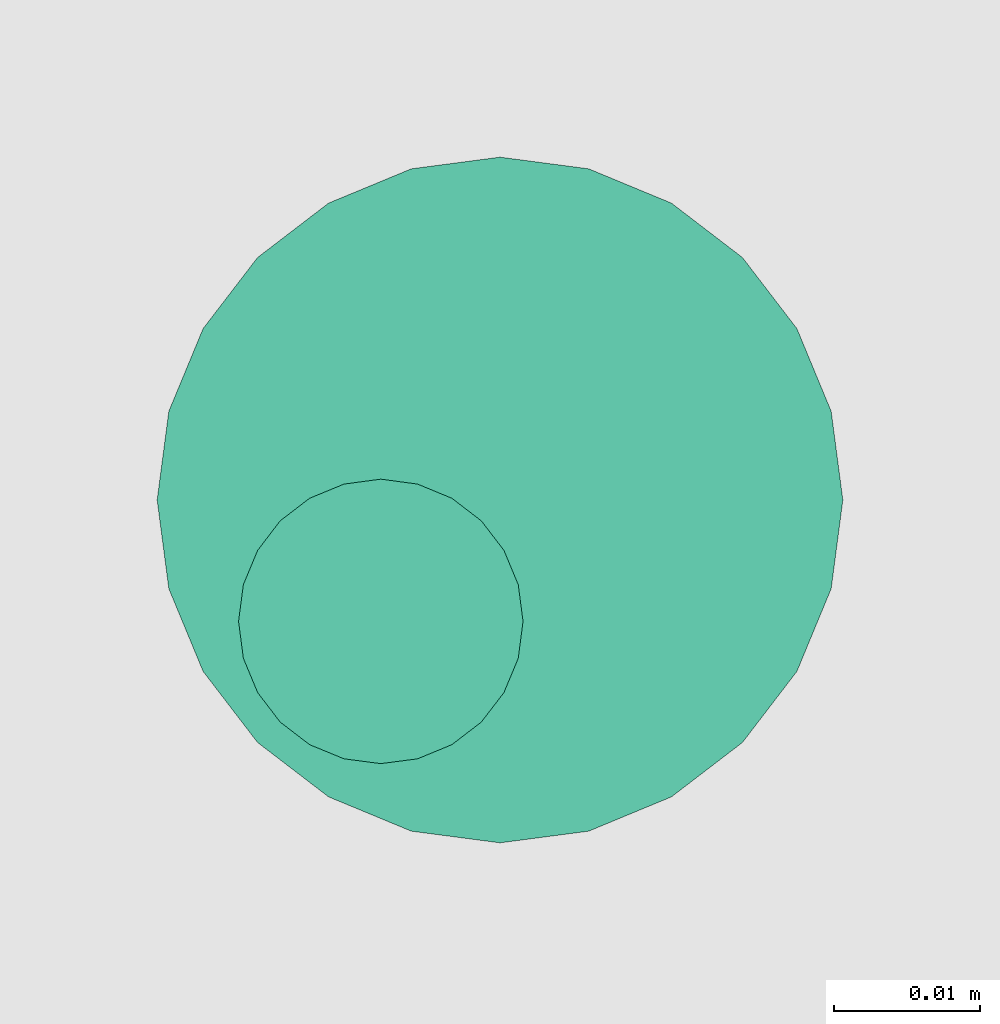
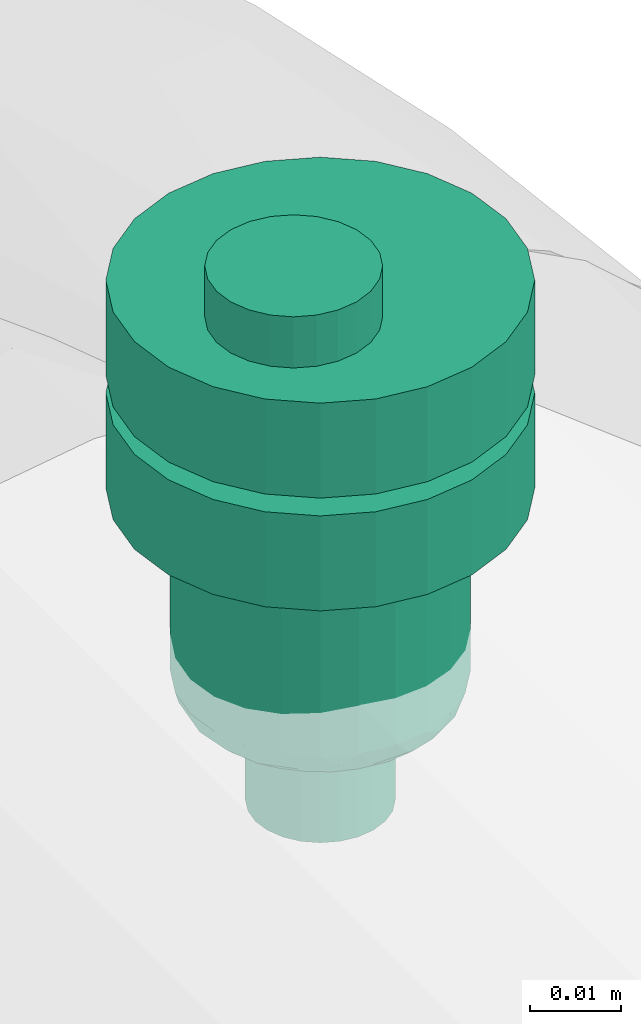
# One storey, part 559 of 827: 1 flow controller.
"""IFC2X3 building model written with IfcOpenShell, lengths in millimetres."""

from ifc_helpers import new_model, entity, si_unit, converted_unit, derived_unit, direction, frame, origin, place, context, subcontext, project, spatial, faceted_brep, source, transform, mapped, material, type_object, type_shapes, element, save


model = new_model("IFC2X3")

# Units and contexts
model_context = context("Model", 3, precision=0.01, world=origin(), true_north=direction((6.12303176911189e-17, 1.0)))
body_context = subcontext(model_context, "Body", "Model", "MODEL_VIEW")
ifc_project = project(units=[si_unit("LENGTHUNIT", "METRE", prefix="MILLI"), si_unit("AREAUNIT", "SQUARE_METRE"), si_unit("VOLUMEUNIT", "CUBIC_METRE"), converted_unit("PLANEANGLEUNIT", "DEGREE", entity("IfcRatioMeasure", 0.0174532925199433), si_unit("PLANEANGLEUNIT", "RADIAN"), dimensions=[0, 0, 0, 0, 0, 0, 0]), si_unit("MASSUNIT", "GRAM", prefix="KILO"), derived_unit("MASSDENSITYUNIT", [(si_unit("MASSUNIT", "GRAM", prefix="KILO"), 1), (si_unit("LENGTHUNIT", "METRE"), -3)]), derived_unit("MOMENTOFINERTIAUNIT", [(si_unit("LENGTHUNIT", "METRE"), 4)]), si_unit("TIMEUNIT", "SECOND"), si_unit("FREQUENCYUNIT", "HERTZ"), si_unit("THERMODYNAMICTEMPERATUREUNIT", "DEGREE_CELSIUS"), derived_unit("THERMALTRANSMITTANCEUNIT", [(si_unit("MASSUNIT", "GRAM", prefix="KILO"), 1), (si_unit("THERMODYNAMICTEMPERATUREUNIT", "KELVIN"), -1), (si_unit("TIMEUNIT", "SECOND"), -3)]), derived_unit("VOLUMETRICFLOWRATEUNIT", [(si_unit("LENGTHUNIT", "METRE"), 3), (si_unit("TIMEUNIT", "SECOND"), -1)]), derived_unit("MASSFLOWRATEUNIT", [(si_unit("MASSUNIT", "GRAM", prefix="KILO"), 1), (si_unit("TIMEUNIT", "SECOND"), -1)]), derived_unit("ROTATIONALFREQUENCYUNIT", [(si_unit("TIMEUNIT", "SECOND"), -1)]), si_unit("ELECTRICCURRENTUNIT", "AMPERE"), si_unit("ELECTRICVOLTAGEUNIT", "VOLT"), si_unit("POWERUNIT", "WATT"), si_unit("FORCEUNIT", "NEWTON", prefix="KILO"), si_unit("ILLUMINANCEUNIT", "LUX"), si_unit("LUMINOUSFLUXUNIT", "LUMEN"), si_unit("LUMINOUSINTENSITYUNIT", "CANDELA"), derived_unit("USERDEFINED", [(si_unit("MASSUNIT", "GRAM", prefix="KILO"), -1), (si_unit("LENGTHUNIT", "METRE"), -2), (si_unit("TIMEUNIT", "SECOND"), 3), (si_unit("LUMINOUSFLUXUNIT", "LUMEN"), 1)]), derived_unit("LINEARVELOCITYUNIT", [(si_unit("LENGTHUNIT", "METRE"), 1), (si_unit("TIMEUNIT", "SECOND"), -1)]), si_unit("PRESSUREUNIT", "PASCAL"), derived_unit("USERDEFINED", [(si_unit("LENGTHUNIT", "METRE"), -2), (si_unit("MASSUNIT", "GRAM", prefix="KILO"), 1), (si_unit("TIMEUNIT", "SECOND"), -2)]), derived_unit("LINEARFORCEUNIT", [(si_unit("MASSUNIT", "GRAM", prefix="KILO"), 1), (si_unit("LENGTHUNIT", "METRE"), 1), (si_unit("TIMEUNIT", "SECOND"), -2), (si_unit("LENGTHUNIT", "METRE"), -1)]), derived_unit("PLANARFORCEUNIT", [(si_unit("MASSUNIT", "GRAM", prefix="KILO"), 1), (si_unit("LENGTHUNIT", "METRE"), 1), (si_unit("TIMEUNIT", "SECOND"), -2), (si_unit("LENGTHUNIT", "METRE"), -2)])], contexts=[model_context])

# Site, building, storey
site_placement = place(None, origin())
site = spatial("IfcSite", under=ifc_project, at=site_placement, CompositionType="ELEMENT")
building_placement = place(site_placement, origin())
building = spatial("IfcBuilding", under=site, at=building_placement, CompositionType="ELEMENT")
storey_placement = place(building_placement, frame((0.0, 0.0, 28200.0)))
storey = spatial("IfcBuildingStorey", under=building, at=storey_placement, Name="08", CompositionType="ELEMENT", Elevation=28200.0)

# Flow controller
ifc_material = material()
valve_type = type_object("IfcValveType", PredefinedType="NOTDEFINED", material=ifc_material)
shared_shape = source(origin(), body_context, "Body", "Brep", [
    faceted_brep([(-6.86, -13.27, -15.58), (-5.66, -12.77, -15.58), (-5.66, -12.77, -13.2), (-6.86, -13.27, -13.2), (-6.86, -13.27, -0.5), (-5.66, -12.77, -0.5), (-5.66, -12.77, 2.49), (-6.86, -13.27, 2.49), (-8.16, -13.44, -15.58), (-8.16, -13.44, -13.2), (-8.16, -13.44, -0.5), (-8.16, -13.44, 2.49), (-3.83, -10.94, -15.58), (-3.33, -9.74, -15.58), (-3.33, -9.74, -13.2), (-3.83, -10.94, -13.2), (-3.83, -10.94, -0.5), (-3.33, -9.74, -0.5), (-3.33, -9.74, 2.49), (-3.83, -10.94, 2.49), (-4.62, -11.98, -15.58), (-4.62, -11.98, -13.2), (-4.62, -11.98, -0.5), (-4.62, -11.98, 2.49), (-3.16, -8.44, -13.2), (-3.16, -8.44, -15.58), (-3.16, -8.44, 2.49), (-3.16, -8.44, -0.5), (-3.83, -5.94, -15.58), (-4.62, -4.91, -15.58), (-4.62, -4.91, -13.2), (-3.83, -5.94, -13.2), (-3.83, -5.94, -0.5), (-4.62, -4.91, -0.5), (-4.62, -4.91, 2.49), (-3.83, -5.94, 2.49), (-3.33, -7.15, -15.58), (-3.33, -7.15, -13.2), (-3.33, -7.15, -0.5), (-3.33, -7.15, 2.49), (-6.86, -3.61, -15.58), (-8.16, -3.44, -15.58), (-8.16, -3.44, -13.2), (-6.86, -3.61, -13.2), (-6.86, -3.61, -0.5), (-8.16, -3.44, -0.5), (-8.16, -3.44, 2.49), (-6.86, -3.61, 2.49), (-5.66, -4.11, -15.58), (-5.66, -4.11, -13.2), (-5.66, -4.11, -0.5), (-5.66, -4.11, 2.49), (-9.45, -3.61, -0.5), (-9.45, -3.61, 2.49), (-9.45, -3.61, -15.58), (-9.45, -3.61, -13.2), (-10.66, -4.11, -0.5), (-10.66, -4.11, 2.49), (-10.66, -4.11, -15.58), (-10.66, -4.11, -13.2), (-12.49, -5.94, 2.49), (-11.69, -4.91, 2.49), (-11.69, -4.91, -0.5), (-12.49, -5.94, -0.5), (-11.69, -4.91, -15.58), (-12.49, -5.94, -15.58), (-12.49, -5.94, -13.2), (-11.69, -4.91, -13.2), (-12.99, -7.15, 2.49), (-12.99, -7.15, -0.5), (-12.99, -7.15, -15.58), (-12.99, -7.15, -13.2), (-13.16, -8.44, 2.49), (-13.16, -8.44, -0.5), (-13.16, -8.44, -13.2), (-13.16, -8.44, -15.58), (-12.49, -10.94, -0.5), (-12.49, -10.94, 2.49), (-12.99, -9.74, 2.49), (-12.99, -9.74, -0.5), (-12.99, -9.74, -15.58), (-12.49, -10.94, -15.58), (-12.49, -10.94, -13.2), (-12.99, -9.74, -13.2), (-11.69, -11.98, -0.5), (-11.69, -11.98, 2.49), (-11.69, -11.98, -15.58), (-11.69, -11.98, -13.2), (-9.45, -13.27, 2.49), (-10.66, -12.77, 2.49), (-10.66, -12.77, -0.5), (-9.45, -13.27, -0.5), (-10.66, -12.77, -15.58), (-9.45, -13.27, -15.58), (-9.45, -13.27, -13.2), (-10.66, -12.77, -13.2), (6.08, -22.7, -0.5), (0.0, -23.5, -0.5), (11.75, -20.35, -0.5), (16.62, -16.62, -0.5), (20.35, -11.75, -0.5), (22.7, -6.08, -0.5), (23.5, 0.0, -0.5), (22.7, 6.08, -0.5), (20.35, 11.75, -0.5), (16.62, 16.62, -0.5), (11.75, 20.35, -0.5), (6.08, 22.7, -0.5), (0.0, 23.5, -0.5), (-6.08, 22.7, -0.5), (-11.75, 20.35, -0.5), (-16.62, 16.62, -0.5), (-20.35, 11.75, -0.5), (-22.7, 6.08, -0.5), (-23.5, 0.0, -0.5), (-22.7, -6.08, -0.5), (-20.35, -11.75, -0.5), (-16.62, -16.62, -0.5), (-11.75, -20.35, -0.5), (-6.08, -22.7, -0.5), (11.75, 20.35, -13.2), (6.08, 22.7, -13.2), (16.62, 16.62, -13.2), (20.35, 11.75, -13.2), (22.7, 6.08, -13.2), (23.5, 0.0, -13.2), (22.7, -6.08, -13.2), (20.35, -11.75, -13.2), (16.62, -16.62, -13.2), (11.75, -20.35, -13.2), (6.08, -22.7, -13.2), (0.0, -23.5, -13.2), (-6.08, -22.7, -13.2), (-11.75, -20.35, -13.2), (-16.62, -16.62, -13.2), (-20.35, -11.75, -13.2), (-22.7, -6.08, -13.2), (-23.5, 0.0, -13.2), (-22.7, 6.08, -13.2), (-20.35, 11.75, -13.2), (-16.62, 16.62, -13.2), (-11.75, 20.35, -13.2), (-6.08, 22.7, -13.2), (0.0, 23.5, -13.2), (-22.7, -6.08, -28.28), (-22.7, -6.08, -15.58), (-23.5, 0.0, -15.58), (-23.5, 0.0, -28.28), (-20.35, -11.75, -28.28), (-20.35, -11.75, -15.58), (-11.75, -20.35, -15.58), (-16.62, -16.62, -15.58), (-16.62, -16.62, -28.28), (-11.75, -20.35, -28.28), (-6.08, -22.7, -15.58), (-6.08, -22.7, -28.28), (0.0, -23.5, -15.58), (0.0, -23.5, -28.28), (6.08, -22.7, -28.28), (6.08, -22.7, -15.58), (11.75, -20.35, -28.28), (11.75, -20.35, -15.58), (20.35, -11.75, -15.58), (16.62, -16.62, -15.58), (16.62, -16.62, -28.28), (20.35, -11.75, -28.28), (22.7, -6.08, -15.58), (22.7, -6.08, -28.28), (23.5, 0.0, -15.58), (23.5, 0.0, -28.28), (22.7, 6.08, -28.28), (22.7, 6.08, -15.58), (20.35, 11.75, -28.28), (20.35, 11.75, -15.58), (11.75, 20.35, -15.58), (16.62, 16.62, -15.58), (16.62, 16.62, -28.28), (11.75, 20.35, -28.28), (6.08, 22.7, -15.58), (6.08, 22.7, -28.28), (0.0, 23.5, -15.58), (0.0, 23.5, -28.28), (-6.08, 22.7, -28.28), (-6.08, 22.7, -15.58), (-11.75, 20.35, -28.28), (-11.75, 20.35, -15.58), (-20.35, 11.75, -15.58), (-16.62, 16.62, -15.58), (-16.62, 16.62, -28.28), (-20.35, 11.75, -28.28), (-22.7, 6.08, -15.58), (-22.7, 6.08, -28.28), (8.23, 14.25, -28.28), (4.26, 15.89, -28.28), (11.63, 11.63, -28.28), (14.25, 8.22, -28.28), (15.89, 4.26, -28.28), (16.45, 0.0, -28.28), (15.89, -4.26, -28.28), (14.25, -8.23, -28.28), (11.63, -11.63, -28.28), (8.23, -14.25, -28.28), (4.26, -15.89, -28.28), (0.0, -16.45, -28.28), (-4.26, -15.89, -28.28), (-8.22, -14.25, -28.28), (-11.63, -11.63, -28.28), (-14.25, -8.23, -28.28), (-15.89, -4.26, -28.28), (-16.45, 0.0, -28.28), (-15.89, 4.26, -28.28), (-14.25, 8.22, -28.28), (-11.63, 11.63, -28.28), (-8.22, 14.25, -28.28), (-4.26, 15.89, -28.28), (0.0, 16.45, -28.28), (-15.89, -4.26, -52.7), (-16.45, 0.0, -52.7), (-14.25, -8.23, -52.7), (-11.63, -11.63, -52.7), (-8.22, -14.25, -52.7), (-4.26, -15.89, -52.7), (0.0, -16.45, -52.7), (4.26, -15.89, -52.7), (8.23, -14.25, -52.7), (11.63, -11.63, -52.7), (14.25, -8.23, -52.7), (15.89, -4.26, -52.7), (16.45, 0.0, -52.7), (15.89, 4.26, -52.7), (14.25, 8.22, -52.7), (11.63, 11.63, -52.7), (8.23, 14.25, -52.7), (4.26, 15.89, -52.7), (0.0, 16.45, -52.7), (-4.26, 15.89, -52.7), (-8.22, 14.25, -52.7), (-11.63, 11.63, -52.7), (-14.25, 8.22, -52.7), (-15.89, 4.26, -52.7), (10.61, 9.36, -56.39), (8.29, 11.45, -56.39), (9.98, 12.23, -54.94), (-13.58, 4.48, -56.31), (-14.89, 5.25, -54.94), (-12.77, 8.5, -55.51), (6.32, 14.92, -54.11), (-3.39, 14.2, -56.13), (-6.26, 13.77, -55.71), (-2.15, 15.69, -54.85), (2.15, 15.59, -55.0), (10.54, 4.37, -56.8), (12.15, 6.9, -56.46), (14.89, 5.25, -54.94), (13.8, 0.0, -56.2), (13.58, 4.48, -56.31), (12.77, 8.5, -55.51), (15.25, 0.0, -55.6), (-9.98, 12.23, -54.94), (6.26, 13.77, -55.71), (4.37, 10.54, -56.8), (3.28, 13.85, -56.34), (-15.25, 0.0, -55.6), (-6.32, 14.92, -54.11), (-10.54, 4.37, -56.8), (-12.35, 0.0, -56.8), (-12.15, 6.9, -56.46), (-10.61, 9.36, -56.39), (8.73, 8.73, -56.8), (-4.37, 10.54, -56.8), (-6.55, 9.64, -56.8), (-13.8, 0.0, -56.2), (-0.21, 14.49, -56.2), (0.0, 12.35, -56.8), (-8.73, 8.73, -56.8), (-8.29, 11.45, -56.39), (12.35, 0.0, -56.8), (-10.61, -9.36, -56.39), (-8.29, -11.45, -56.39), (-9.98, -12.23, -54.94), (13.58, -4.48, -56.31), (14.89, -5.25, -54.94), (12.77, -8.5, -55.51), (-6.32, -14.92, -54.11), (6.32, -14.92, -54.11), (9.98, -12.23, -54.94), (-2.15, -15.59, -55.0), (-10.54, -4.37, -56.8), (-12.15, -6.9, -56.46), (-12.77, -8.5, -55.51), (2.15, -15.69, -54.85), (-14.89, -5.25, -54.94), (-13.58, -4.48, -56.31), (-8.73, -8.73, -56.8), (6.26, -13.77, -55.71), (4.37, -10.54, -56.8), (6.55, -9.64, -56.8), (12.15, -6.9, -56.46), (10.61, -9.36, -56.39), (10.54, -4.37, -56.8), (-6.26, -13.77, -55.71), (-4.37, -10.54, -56.8), (-3.28, -13.85, -56.34), (3.39, -14.2, -56.13), (0.21, -14.49, -56.2), (0.0, -12.35, -56.8), (8.73, -8.73, -56.8), (8.29, -11.45, -56.39), (-7.94, 2.13, -56.8), (-8.22, 0.0, -56.8), (-7.12, 4.11, -56.8), (-7.94, -2.13, -56.8), (-7.12, -4.11, -56.8), (-5.82, -5.82, -56.8), (-4.11, -7.12, -56.8), (-2.13, -7.94, -56.8), (0.0, -8.23, -56.8), (2.13, -7.94, -56.8), (4.11, -7.12, -56.8), (5.82, -5.82, -56.8), (7.12, -4.11, -56.8), (7.94, -2.13, -56.8), (8.23, 0.0, -56.8), (7.94, 2.13, -56.8), (7.12, 4.11, -56.8), (5.82, 5.82, -56.8), (4.11, 7.12, -56.8), (2.13, 7.94, -56.8), (0.0, 8.22, -56.8), (-2.13, 7.94, -56.8), (-4.11, 7.12, -56.8), (-5.82, 5.82, -56.8), (0.0, 8.22, -70.0), (2.13, 7.94, -70.0), (4.11, 7.12, -70.0), (5.82, 5.82, -70.0), (7.12, 4.11, -70.0), (7.94, 2.13, -70.0), (8.23, 0.0, -70.0), (7.94, -2.13, -70.0), (7.12, -4.11, -70.0), (5.82, -5.82, -70.0), (4.11, -7.12, -70.0), (2.13, -7.94, -70.0), (0.0, -8.23, -70.0), (-2.13, -7.94, -70.0), (-4.11, -7.12, -70.0), (-5.82, -5.82, -70.0), (-7.12, -4.11, -70.0), (-7.94, -2.13, -70.0), (-8.22, 0.0, -70.0), (-7.94, 2.13, -70.0), (-7.12, 4.11, -70.0), (-5.82, 5.82, -70.0), (-4.11, 7.12, -70.0), (-2.13, 7.94, -70.0), (1.25, -5.8, 9.33), (0.27, -3.45, 9.33), (-1.28, -1.43, 9.33), (-3.3, 0.12, 9.33), (-5.65, 1.09, 9.33), (-8.17, 1.43, 9.33), (-10.69, 1.09, 9.33), (-13.05, 0.12, 9.33), (-15.07, -1.43, 9.33), (-16.61, -3.45, 9.33), (-17.59, -5.8, 9.33), (-17.92, -8.32, 9.33), (-17.59, -10.85, 9.33), (-16.61, -13.2, 9.33), (-15.07, -15.22, 9.33), (-13.05, -16.77, 9.33), (-10.69, -17.74, 9.33), (-8.17, -18.07, 9.33), (-5.65, -17.74, 9.33), (-3.3, -16.77, 9.33), (-1.28, -15.22, 9.33), (0.27, -13.2, 9.33), (1.25, -10.85, 9.33), (1.58, -8.32, 9.33), (-16.61, -3.45, 2.49), (-17.59, -5.8, 2.49), (-15.07, -1.43, 2.49), (-13.05, 0.12, 2.49), (-10.69, 1.09, 2.49), (-8.17, 1.43, 2.49), (-5.65, 1.09, 2.49), (-3.3, 0.12, 2.49), (-1.28, -1.43, 2.49), (0.27, -3.45, 2.49), (1.25, -5.8, 2.49), (1.58, -8.32, 2.49), (1.25, -10.85, 2.49), (0.27, -13.2, 2.49), (-1.28, -15.22, 2.49), (-3.3, -16.77, 2.49), (-5.65, -17.74, 2.49), (-8.17, -18.07, 2.49), (-10.69, -17.74, 2.49), (-13.05, -16.77, 2.49), (-15.07, -15.22, 2.49), (-16.61, -13.2, 2.49), (-17.59, -10.85, 2.49), (-17.92, -8.32, 2.49)], [[[0, 1, 2, 3]], [[4, 5, 6, 7]], [[8, 0, 3, 9]], [[10, 4, 7, 11]], [[12, 13, 14, 15]], [[16, 17, 18, 19]], [[20, 12, 15, 21]], [[22, 16, 19, 23]], [[1, 20, 21, 2]], [[5, 22, 23, 6]], [[24, 14, 13, 25]], [[26, 18, 17, 27]], [[28, 29, 30, 31]], [[32, 33, 34, 35]], [[36, 28, 31, 37]], [[38, 32, 35, 39]], [[40, 41, 42, 43]], [[44, 45, 46, 47]], [[48, 40, 43, 49]], [[50, 44, 47, 51]], [[29, 48, 49, 30]], [[33, 50, 51, 34]], [[36, 37, 24, 25]], [[38, 39, 26, 27]], [[52, 53, 46, 45]], [[41, 54, 55, 42]], [[56, 57, 53, 52]], [[54, 58, 59, 55]], [[60, 61, 62, 63]], [[64, 65, 66, 67]], [[56, 62, 61, 57]], [[58, 64, 67, 59]], [[68, 60, 63, 69]], [[65, 70, 71, 66]], [[72, 68, 69, 73]], [[74, 71, 70, 75]], [[76, 77, 78, 79]], [[80, 81, 82, 83]], [[84, 85, 77, 76]], [[81, 86, 87, 82]], [[88, 89, 90, 91]], [[92, 93, 94, 95]], [[84, 90, 89, 85]], [[86, 92, 95, 87]], [[11, 88, 91, 10]], [[93, 8, 9, 94]], [[79, 78, 72, 73]], [[80, 83, 74, 75]], [[96, 16, 97]], [[16, 96, 17]], [[98, 17, 96]], [[27, 17, 98]], [[98, 99, 27]], [[100, 27, 99]], [[100, 38, 27]], [[38, 100, 101]], [[38, 101, 102]], [[38, 102, 32]], [[32, 102, 103]], [[104, 32, 103]], [[104, 33, 32]], [[104, 105, 33]], [[105, 106, 33]], [[106, 50, 33]], [[50, 106, 107]], [[50, 107, 108]], [[108, 44, 50]], [[44, 108, 109]], [[44, 109, 110]], [[110, 45, 44]], [[45, 110, 111]], [[45, 111, 112]], [[52, 45, 112]], [[52, 112, 113]], [[56, 52, 113]], [[113, 114, 56]], [[114, 62, 56]], [[62, 114, 63]], [[114, 115, 63]], [[115, 69, 63]], [[73, 69, 115]], [[115, 116, 73]], [[116, 79, 73]], [[79, 116, 76]], [[76, 116, 117]], [[76, 117, 84]], [[117, 90, 84]], [[118, 90, 117]], [[90, 118, 91]], [[10, 91, 118]], [[10, 118, 119]], [[97, 5, 119]], [[119, 5, 4]], [[10, 119, 4]], [[22, 97, 16]], [[22, 5, 97]], [[120, 49, 121]], [[49, 120, 30]], [[122, 30, 120]], [[122, 123, 30]], [[30, 123, 31]], [[123, 124, 31]], [[31, 124, 125]], [[37, 31, 125]], [[37, 125, 126]], [[127, 37, 126]], [[37, 127, 24]], [[127, 128, 24]], [[129, 24, 128]], [[14, 24, 129]], [[129, 130, 14]], [[130, 15, 14]], [[130, 131, 15]], [[131, 21, 15]], [[2, 21, 131]], [[2, 131, 132]], [[2, 132, 3]], [[3, 132, 9]], [[132, 133, 9]], [[94, 9, 133]], [[133, 95, 94]], [[95, 133, 134]], [[95, 134, 87]], [[82, 87, 134]], [[135, 82, 134]], [[135, 83, 82]], [[74, 83, 135]], [[135, 136, 74]], [[74, 136, 71]], [[71, 136, 66]], [[66, 136, 137]], [[137, 67, 66]], [[67, 137, 59]], [[137, 138, 59]], [[59, 138, 55]], [[139, 55, 138]], [[55, 139, 42]], [[140, 42, 139]], [[141, 42, 140]], [[42, 141, 43]], [[141, 142, 43]], [[43, 142, 143]], [[121, 49, 143]], [[43, 143, 49]], [[136, 115, 114, 137]], [[144, 145, 146, 147]], [[135, 116, 115, 136]], [[148, 149, 145, 144]], [[118, 117, 134, 133]], [[150, 151, 152, 153]], [[135, 134, 117, 116]], [[148, 152, 151, 149]], [[119, 118, 133, 132]], [[154, 150, 153, 155]], [[97, 119, 132, 131]], [[156, 154, 155, 157]], [[130, 96, 97, 131]], [[158, 159, 156, 157]], [[129, 98, 96, 130]], [[160, 161, 159, 158]], [[100, 99, 128, 127]], [[162, 163, 164, 165]], [[129, 128, 99, 98]], [[160, 164, 163, 161]], [[101, 100, 127, 126]], [[166, 162, 165, 167]], [[102, 101, 126, 125]], [[168, 166, 167, 169]], [[124, 103, 102, 125]], [[170, 171, 168, 169]], [[123, 104, 103, 124]], [[172, 173, 171, 170]], [[106, 105, 122, 120]], [[174, 175, 176, 177]], [[123, 122, 105, 104]], [[172, 176, 175, 173]], [[107, 106, 120, 121]], [[178, 174, 177, 179]], [[108, 107, 121, 143]], [[180, 178, 179, 181]], [[142, 109, 108, 143]], [[182, 183, 180, 181]], [[141, 110, 109, 142]], [[184, 185, 183, 182]], [[112, 111, 140, 139]], [[186, 187, 188, 189]], [[141, 140, 111, 110]], [[184, 188, 187, 185]], [[113, 112, 139, 138]], [[190, 186, 189, 191]], [[114, 113, 138, 137]], [[146, 190, 191, 147]], [[159, 12, 156]], [[12, 159, 13]], [[161, 13, 159]], [[25, 13, 161]], [[161, 163, 25]], [[162, 25, 163]], [[162, 36, 25]], [[36, 162, 166]], [[36, 166, 168]], [[36, 168, 28]], [[28, 168, 171]], [[173, 28, 171]], [[173, 29, 28]], [[173, 175, 29]], [[175, 174, 29]], [[174, 48, 29]], [[48, 174, 178]], [[48, 178, 180]], [[180, 40, 48]], [[40, 180, 183]], [[40, 183, 185]], [[185, 41, 40]], [[41, 185, 187]], [[41, 187, 186]], [[54, 41, 186]], [[54, 186, 190]], [[58, 54, 190]], [[190, 146, 58]], [[146, 64, 58]], [[64, 146, 65]], [[146, 145, 65]], [[145, 70, 65]], [[75, 70, 145]], [[145, 149, 75]], [[149, 80, 75]], [[80, 149, 81]], [[81, 149, 151]], [[81, 151, 86]], [[151, 92, 86]], [[150, 92, 151]], [[92, 150, 93]], [[8, 93, 150]], [[8, 150, 154]], [[156, 1, 154]], [[154, 1, 0]], [[8, 154, 0]], [[20, 156, 12]], [[20, 1, 156]], [[177, 176, 192]], [[177, 192, 193]], [[193, 179, 177]], [[192, 176, 194]], [[172, 194, 176]], [[195, 194, 172]], [[196, 195, 172]], [[196, 172, 170]], [[196, 170, 197]], [[197, 170, 169]], [[198, 197, 169]], [[198, 169, 167]], [[199, 198, 167]], [[199, 167, 165]], [[200, 199, 165]], [[165, 164, 200]], [[164, 201, 200]], [[201, 164, 160]], [[201, 160, 202]], [[158, 202, 160]], [[202, 158, 203]], [[203, 158, 157]], [[157, 204, 203]], [[204, 157, 155]], [[204, 155, 205]], [[153, 205, 155]], [[153, 206, 205]], [[153, 152, 206]], [[207, 206, 152]], [[148, 207, 152]], [[144, 207, 148]], [[208, 207, 144]], [[208, 144, 147]], [[147, 209, 208]], [[191, 209, 147]], [[191, 210, 209]], [[210, 191, 189]], [[211, 210, 189]], [[211, 189, 188]], [[211, 188, 212]], [[188, 184, 212]], [[212, 184, 213]], [[213, 184, 182]], [[182, 214, 213]], [[181, 214, 182]], [[179, 215, 181]], [[214, 181, 215]], [[179, 193, 215]], [[216, 208, 209, 217]], [[218, 207, 208, 216]], [[205, 206, 219, 220]], [[218, 219, 206, 207]], [[204, 205, 220, 221]], [[221, 222, 203, 204]], [[202, 223, 224, 201]], [[225, 200, 201, 224]], [[199, 226, 227, 198]], [[225, 226, 199, 200]], [[198, 227, 228, 197]], [[223, 202, 203, 222]], [[229, 196, 197, 228]], [[230, 195, 196, 229]], [[192, 194, 231, 232]], [[230, 231, 194, 195]], [[193, 192, 232, 233]], [[193, 233, 234, 215]], [[214, 235, 236, 213]], [[237, 212, 213, 236]], [[211, 238, 239, 210]], [[237, 238, 211, 212]], [[210, 239, 217, 209]], [[235, 214, 215, 234]], [[240, 241, 242]], [[243, 244, 245]], [[246, 233, 232]], [[247, 248, 249]], [[233, 246, 250]], [[251, 240, 252]], [[253, 254, 255]], [[231, 256, 242]], [[229, 257, 253]], [[228, 257, 229]], [[230, 253, 256]], [[253, 255, 256]], [[229, 253, 230]], [[236, 258, 237]], [[242, 232, 231]], [[259, 260, 261]], [[249, 234, 250]], [[262, 239, 244]], [[230, 256, 231]], [[235, 263, 236]], [[244, 239, 238]], [[243, 264, 265]], [[263, 258, 236]], [[241, 260, 259]], [[234, 249, 235]], [[245, 244, 238]], [[233, 250, 234]], [[258, 245, 237]], [[266, 267, 264]], [[238, 237, 245]], [[240, 251, 268]], [[248, 269, 270]], [[262, 217, 239]], [[243, 271, 244]], [[246, 242, 259]], [[258, 267, 245]], [[240, 256, 252]], [[240, 242, 256]], [[247, 249, 272]], [[263, 249, 248]], [[273, 272, 261]], [[272, 249, 250]], [[274, 267, 275]], [[270, 274, 275]], [[241, 240, 268]], [[275, 258, 248]], [[264, 267, 274]], [[261, 272, 250]], [[247, 273, 269]], [[259, 261, 250]], [[273, 261, 260]], [[273, 247, 272]], [[269, 248, 247]], [[266, 245, 267]], [[251, 255, 276]], [[254, 253, 257]], [[254, 276, 255]], [[271, 262, 244]], [[243, 265, 271]], [[260, 241, 268]], [[242, 241, 259]], [[258, 275, 267]], [[270, 275, 248]], [[242, 246, 232]], [[250, 246, 259]], [[249, 263, 235]], [[258, 263, 248]], [[256, 255, 252]], [[255, 251, 252]], [[264, 243, 266]], [[243, 245, 266]], [[277, 278, 279]], [[280, 281, 282]], [[283, 221, 220]], [[284, 285, 224]], [[221, 283, 286]], [[287, 277, 288]], [[277, 289, 288]], [[219, 289, 279]], [[290, 222, 286]], [[217, 262, 216]], [[218, 291, 289]], [[291, 292, 289]], [[277, 287, 293]], [[216, 291, 218]], [[279, 220, 219]], [[294, 295, 296]], [[224, 285, 225]], [[257, 227, 281]], [[297, 298, 299]], [[226, 281, 227]], [[226, 225, 282]], [[291, 271, 292]], [[227, 257, 228]], [[226, 282, 281]], [[277, 279, 289]], [[218, 289, 219]], [[300, 301, 302]], [[290, 223, 222]], [[280, 254, 281]], [[223, 284, 224]], [[285, 282, 225]], [[221, 286, 222]], [[278, 301, 300]], [[303, 294, 290]], [[216, 262, 291]], [[285, 298, 282]], [[283, 279, 300]], [[280, 299, 276]], [[303, 290, 304]], [[284, 290, 294]], [[305, 304, 302]], [[304, 290, 286]], [[306, 298, 307]], [[296, 306, 307]], [[278, 277, 293]], [[307, 285, 294]], [[299, 298, 306]], [[302, 304, 286]], [[303, 305, 295]], [[300, 302, 286]], [[305, 302, 301]], [[305, 303, 304]], [[295, 294, 303]], [[297, 282, 298]], [[287, 292, 265]], [[271, 291, 262]], [[271, 265, 292]], [[254, 257, 281]], [[280, 276, 254]], [[301, 278, 293]], [[279, 278, 300]], [[285, 307, 298]], [[296, 307, 294]], [[279, 283, 220]], [[286, 283, 300]], [[290, 284, 223]], [[285, 284, 294]], [[289, 292, 288]], [[292, 287, 288]], [[299, 280, 297]], [[280, 282, 297]], [[308, 309, 265]], [[308, 265, 264]], [[308, 264, 274]], [[310, 308, 274]], [[311, 265, 309]], [[311, 287, 265]], [[311, 293, 287]], [[312, 293, 311]], [[312, 313, 293]], [[313, 314, 293]], [[314, 301, 293]], [[314, 305, 301]], [[305, 314, 315]], [[315, 316, 305]], [[316, 317, 305]], [[318, 305, 317]], [[318, 295, 305]], [[318, 296, 295]], [[318, 306, 296]], [[319, 306, 318]], [[320, 306, 319]], [[306, 320, 321]], [[321, 299, 306]], [[321, 276, 299]], [[322, 276, 321]], [[323, 276, 322]], [[323, 251, 276]], [[323, 268, 251]], [[323, 324, 268]], [[324, 325, 268]], [[268, 325, 326]], [[326, 260, 268]], [[326, 273, 260]], [[326, 327, 273]], [[328, 273, 327]], [[328, 329, 273]], [[329, 330, 273]], [[330, 331, 274]], [[330, 274, 270]], [[330, 270, 269]], [[330, 269, 273]], [[310, 274, 331]], [[332, 333, 334, 335, 336, 337, 338, 339, 340, 341, 342, 343, 344, 345, 346, 347, 348, 349, 350, 351, 352, 353, 354, 355]], [[349, 311, 309, 350]], [[348, 312, 311, 349]], [[314, 313, 347, 346]], [[348, 347, 313, 312]], [[315, 314, 346, 345]], [[316, 315, 345, 344]], [[343, 317, 316, 344]], [[342, 318, 317, 343]], [[320, 319, 341, 340]], [[342, 341, 319, 318]], [[321, 320, 340, 339]], [[322, 321, 339, 338]], [[337, 323, 322, 338]], [[336, 324, 323, 337]], [[326, 325, 335, 334]], [[336, 335, 325, 324]], [[327, 326, 334, 333]], [[328, 327, 333, 332]], [[355, 329, 328, 332]], [[354, 330, 329, 355]], [[310, 331, 353, 352]], [[354, 353, 331, 330]], [[308, 310, 352, 351]], [[309, 308, 351, 350]], [[356, 357, 358, 359, 360, 361, 362, 363, 364, 365, 366, 367, 368, 369, 370, 371, 372, 373, 374, 375, 376, 377, 378, 379]], [[380, 60, 381]], [[60, 380, 61]], [[382, 61, 380]], [[61, 382, 57]], [[382, 383, 57]], [[53, 57, 383]], [[384, 53, 383]], [[53, 384, 46]], [[46, 384, 385]], [[386, 46, 385]], [[46, 386, 47]], [[386, 387, 47]], [[51, 47, 387]], [[388, 51, 387]], [[388, 34, 51]], [[388, 389, 34]], [[389, 35, 34]], [[389, 390, 35]], [[39, 35, 390]], [[39, 390, 391]], [[39, 391, 26]], [[392, 26, 391]], [[18, 26, 392]], [[18, 392, 393]], [[19, 18, 393]], [[19, 393, 394]], [[23, 19, 394]], [[394, 395, 23]], [[395, 6, 23]], [[396, 6, 395]], [[396, 7, 6]], [[7, 396, 397]], [[7, 397, 11]], [[11, 397, 88]], [[398, 88, 397]], [[88, 398, 89]], [[89, 398, 399]], [[89, 399, 85]], [[399, 400, 85]], [[85, 400, 77]], [[401, 77, 400]], [[77, 401, 78]], [[402, 78, 401]], [[402, 72, 78]], [[72, 402, 403]], [[403, 381, 68]], [[403, 68, 72]], [[60, 68, 381]], [[396, 374, 373, 397]], [[395, 375, 374, 396]], [[377, 376, 394, 393]], [[395, 394, 376, 375]], [[378, 377, 393, 392]], [[379, 378, 392, 391]], [[390, 356, 379, 391]], [[389, 357, 356, 390]], [[359, 358, 388, 387]], [[389, 388, 358, 357]], [[360, 359, 387, 386]], [[361, 360, 386, 385]], [[384, 362, 361, 385]], [[383, 363, 362, 384]], [[365, 364, 382, 380]], [[383, 382, 364, 363]], [[366, 365, 380, 381]], [[367, 366, 381, 403]], [[402, 368, 367, 403]], [[401, 369, 368, 402]], [[371, 370, 400, 399]], [[401, 400, 370, 369]], [[372, 371, 399, 398]], [[373, 372, 398, 397]]]),
])
type_shapes(valve_type, [shared_shape])
flow_controller_placement = place(storey_placement, frame((27120.33, 11599.11, 3590.0)))
element("IfcFlowController", 1, at=flow_controller_placement, inside=storey, type_object=valve_type, material=ifc_material, context=body_context, shape_type="MappedRepresentation", body=[
    mapped(shared_shape, transform((0.0, 0.0, 0.0), scale=1.0)),
])

save(model, "model.ifc")
